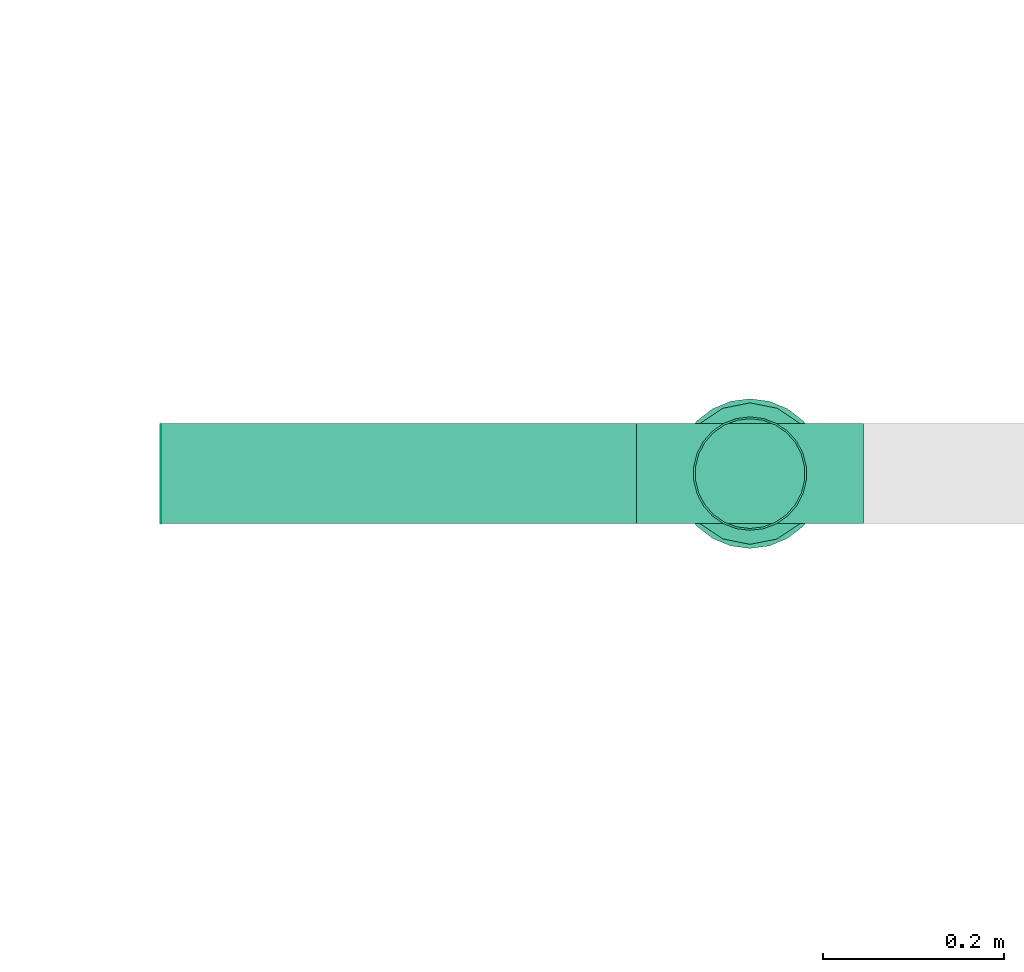
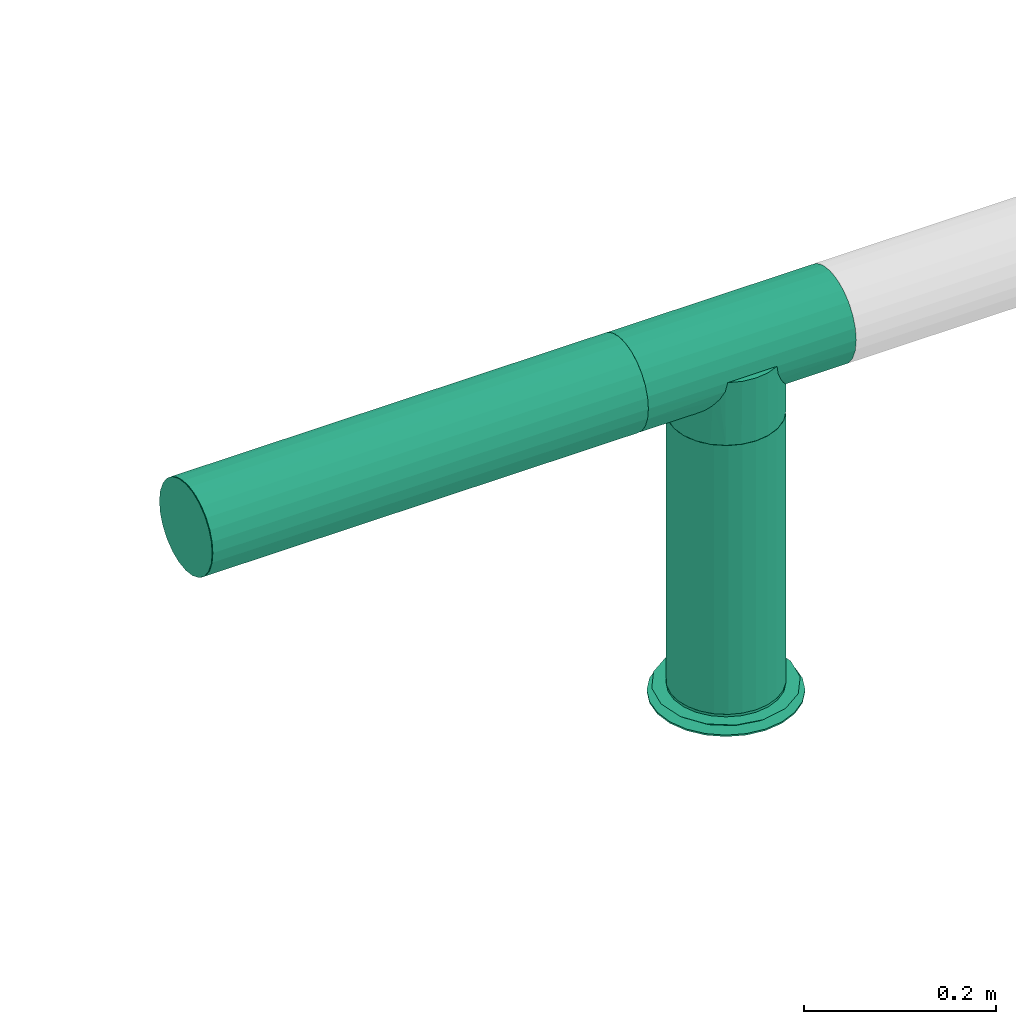
# One storey, part 41 of 123: 2 flow fittings, 2 flow segments, 1 flow terminal.
"""IFC2X3 building model written with IfcOpenShell, lengths in millimetres."""

from ifc_helpers import new_model, entity, si_unit, converted_unit, derived_unit, direction, frame, origin_with_axes, origin_2d_with_axis, place, context, subcontext, project, spatial, hollow_circle, extrude, open_shell, surface_model, source, transform, mapped, material, layer, layer_set, layer_usage, type_object, element, save


model = new_model("IFC2X3")

# Units and contexts
model_context = context("Model", 3, precision=1e-05, world=origin_with_axes(), true_north=direction((0.0, 1.0)))
body_context = subcontext(model_context, "Body", "Model", "MODEL_VIEW")
ifc_project = project(units=[si_unit("AREAUNIT", "SQUARE_METRE"), si_unit("VOLUMEUNIT", "CUBIC_METRE", prefix="DECI"), si_unit("TIMEUNIT", "SECOND"), si_unit("THERMODYNAMICTEMPERATUREUNIT", "DEGREE_CELSIUS"), si_unit("PRESSUREUNIT", "PASCAL"), si_unit("MASSUNIT", "GRAM", prefix="KILO"), si_unit("LENGTHUNIT", "METRE", prefix="MILLI"), si_unit("POWERUNIT", "WATT"), si_unit("ELECTRICCURRENTUNIT", "AMPERE"), si_unit("ELECTRICVOLTAGEUNIT", "VOLT"), derived_unit("VOLUMETRICFLOWRATEUNIT", [(si_unit("VOLUMEUNIT", "CUBIC_METRE", prefix="DECI"), 1), (si_unit("TIMEUNIT", "SECOND"), -1)]), derived_unit("LINEARVELOCITYUNIT", [(si_unit("LENGTHUNIT", "METRE"), 1), (si_unit("TIMEUNIT", "SECOND"), -1)]), derived_unit("MASSDENSITYUNIT", [(si_unit("MASSUNIT", "GRAM", prefix="KILO"), 1), (si_unit("VOLUMEUNIT", "CUBIC_METRE"), -1)]), converted_unit("PLANEANGLEUNIT", "DEGREE", entity("IfcRatioMeasure", 0.01745), si_unit("PLANEANGLEUNIT", "RADIAN"), dimensions=[0, 0, 0, 0, 0, 0, 0])], contexts=[model_context])

# Site, building, storey
site_placement = place(None, origin_with_axes())
site = spatial("IfcSite", under=ifc_project, at=site_placement, CompositionType="ELEMENT")
building_placement = place(site_placement, origin_with_axes())
building = spatial("IfcBuilding", under=site, at=building_placement, Name="mc-building", CompositionType="ELEMENT")
storey_placement = place(building_placement, origin_with_axes())
storey = spatial("IfcBuildingStorey", under=building, at=storey_placement, Name="1. Korrus", CompositionType="ELEMENT", Elevation=0.0)

# Flow terminal
air_terminal_type = type_object("IfcAirTerminalType", Name="125", PredefinedType="NOTDEFINED")
shared_shape_1 = source(origin_with_axes(), body_context, "Body", "SurfaceModel", [
    surface_model("IfcShellBasedSurfaceModel", [(11.2, 41.25, -71.4471), (11.2, 0.0, -82.5), (11.2, 21.35257, -79.68888), (11.2, 71.4471, -41.25), (11.2, 58.33631, -58.33631), (11.2, 79.68888, -21.35257), (11.2, 82.5, 0.0), (11.2, -79.68888, -21.35257), (11.2, -41.25, -71.4471), (11.2, -21.35257, -79.68888), (11.2, -58.33631, -58.33631), (11.2, -71.4471, -41.25), (11.2, 79.68888, 21.35257), (11.2, 71.4471, 41.25), (11.2, 58.33631, 58.33631), (11.2, 41.25, 71.4471), (11.2, 21.35257, 79.68888), (11.2, -58.33631, 58.33631), (11.2, -21.35257, 79.68888), (11.2, 0.0, 82.5), (11.2, -79.68888, 21.35257), (11.2, -71.4471, 41.25), (11.2, -82.5, 0.0), (11.2, -41.25, 71.4471), (9.2, 21.35257, 79.68888), (9.2, -21.35257, 79.68888), (9.2, 0.0, 82.5), (9.2, 58.33631, 58.33631), (9.2, 41.25, 71.4471), (9.2, 71.4471, 41.25), (9.2, 79.68888, 21.35257), (9.2, -58.33631, 58.33631), (9.2, -41.25, 71.4471), (9.2, -79.68888, 21.35257), (9.2, -71.4471, 41.25), (9.2, -58.33631, -58.33631), (9.2, -82.5, 0.0), (9.2, 79.68888, -21.35257), (9.2, 41.25, -71.4471), (9.2, 71.4471, -41.25), (9.2, -41.25, -71.4471), (9.2, 58.33631, -58.33631), (9.2, 0.0, -82.5), (9.2, 21.35257, -79.68888), (9.2, -71.4471, -41.25), (9.2, -79.68888, -21.35257), (9.2, -21.35257, -79.68888), (9.2, 82.5, 0.0), (9.2, 19.5, 33.77499), (9.2, 0.0, 39.0), (9.2, -19.5, 33.77499), (9.2, -39.0, 0.0), (9.2, 33.77499, 19.5), (9.2, 39.0, 0.0), (9.2, -33.77499, 19.5), (9.2, 0.0, -39.0), (9.2, -33.77499, -19.5), (9.2, -19.5, -33.77499), (9.2, 33.77499, -19.5), (9.2, 19.5, -33.77499), (6.2, 25.24133, 18.3389), (6.2, 31.2, 0.0), (6.2, 9.64133, 29.67296), (6.2, -25.24133, 18.3389), (6.2, -9.64133, 29.67296), (6.2, -31.2, 0.0), (6.2, 25.24133, -18.3389), (6.2, 9.64133, -29.67296), (6.2, -9.64133, -29.67296), (6.2, -25.24133, -18.3389), (9.2, 37.1621, -6.85914), (6.2, 28.22067, -9.16945), (9.2, 35.3242, -13.71829), (6.2, -17.44133, -24.00593), (9.2, -26.6375, -26.6375), (6.2, -28.22067, -9.16945), (9.2, -37.1621, -6.85914), (6.2, 17.44133, -24.00593), (9.2, 9.75, -36.3875), (6.2, 0.0, -29.67296), (9.2, -35.3242, -13.71829), (9.2, 26.6375, -26.6375), (9.2, -9.75, -36.3875), (9.2, -37.1621, 6.85914), (6.2, -28.22067, 9.16945), (9.2, -35.3242, 13.71829), (6.2, 17.44133, 24.00593), (9.2, 26.6375, 26.6375), (6.2, 28.22067, 9.16945), (9.2, 37.1621, 6.85914), (6.2, -17.44133, 24.00593), (9.2, -9.75, 36.3875), (6.2, 0.0, 29.67296), (9.2, 35.3242, 13.71829), (9.2, -26.6375, 26.6375), (9.2, 9.75, 36.3875), (6.2, -26.86438, 64.85634), (6.2, -49.63889, 49.63889), (6.2, -64.85634, 26.86438), (6.2, -70.2, 0.0), (6.2, 64.85634, 26.86438), (6.2, 0.0, 70.2), (6.2, 26.86438, 64.85634), (6.2, 49.63889, 49.63889), (6.2, 70.2, 0.0), (6.2, -64.85634, -26.86438), (6.2, -49.63889, -49.63889), (6.2, -26.86438, -64.85634), (6.2, 26.86438, -64.85634), (6.2, 0.0, -70.2), (6.2, 64.85634, -26.86438), (6.2, 49.63889, -49.63889), (0.0, -29.84931, 72.0626), (0.0, 0.0, 78.0), (0.0, 29.84931, 72.0626), (0.0, 55.15433, 55.15433), (0.0, 78.0, 0.0), (0.0, -55.15433, 55.15433), (0.0, -72.0626, 29.84931), (0.0, -78.0, 0.0), (0.0, 72.0626, 29.84931), (0.0, -72.0626, -29.84931), (0.0, 72.0626, -29.84931), (0.0, 55.15433, -55.15433), (0.0, 29.84931, -72.0626), (0.0, -55.15433, -55.15433), (0.0, -29.84931, -72.0626), (0.0, 0.0, -78.0), (6.2, 66.75025, -17.34304), (0.0, 63.60847, -42.50182), (6.2, 57.24762, -38.25164), (0.0, -14.92465, -75.0313), (6.2, -13.43219, -67.52817), (0.0, 42.50182, -63.60847), (6.2, 38.25164, -57.24762), (0.0, 75.0313, -14.92465), (0.0, 14.92465, -75.0313), (6.2, 13.43219, -67.52817), (0.0, -74.16695, -19.27005), (6.2, -67.52817, -13.43219), (0.0, -42.50182, -63.60847), (6.2, -38.25164, -57.24762), (0.0, -63.60847, -42.50182), (6.2, -57.24762, -38.25164), (6.2, -66.75025, 17.34304), (0.0, -63.60847, 42.50182), (6.2, -57.24762, 38.25164), (0.0, 14.92465, 75.0313), (6.2, 13.43219, 67.52817), (0.0, -42.50182, 63.60847), (6.2, -38.25164, 57.24762), (0.0, -75.0313, 14.92465), (0.0, -14.92465, 75.0313), (6.2, -13.43219, 67.52817), (0.0, 74.16695, 19.27005), (6.2, 67.52817, 13.43219), (0.0, 42.50182, 63.60847), (6.2, 38.25164, 57.24762), (0.0, 63.60847, 42.50182), (6.2, 57.24762, 38.25164), (-3.1, 16.17619, 60.37037), (-3.1, -31.25, 54.12659), (-3.1, 0.0, 62.5), (-3.1, 54.12659, 31.25), (-3.1, 31.25, 54.12659), (-3.1, 44.19417, 44.19417), (-3.1, -54.12659, -31.25), (-3.1, -54.12659, 31.25), (-3.1, -44.19417, 44.19417), (-3.1, -16.17619, 60.37037), (-3.1, -62.5, 0.0), (-3.1, -60.37037, 16.17619), (-3.1, 60.37037, 16.17619), (-3.1, 62.5, 0.0), (-3.1, 60.37037, -16.17619), (-3.1, 54.12659, -31.25), (-3.1, 44.19417, -44.19417), (-3.1, 31.25, -54.12659), (-3.1, 16.17619, -60.37037), (-3.1, -31.25, -54.12659), (-3.1, -44.19417, -44.19417), (-3.1, -60.37037, -16.17619), (-3.1, 0.0, -62.5), (-3.1, -16.17619, -60.37037), (0.0, 31.25, -54.12659), (0.0, -54.12659, -31.25), (0.0, 16.17619, -60.37037), (0.0, 54.12659, -31.25), (0.0, 44.19417, -44.19417), (0.0, 60.37037, -16.17619), (0.0, 62.5, 0.0), (0.0, 54.12659, 31.25), (0.0, 16.17619, 60.37037), (0.0, 0.0, -62.5), (0.0, -31.25, -54.12659), (0.0, -16.17619, -60.37037), (0.0, -44.19417, -44.19417), (0.0, -62.5, 0.0), (0.0, -60.37037, -16.17619), (0.0, 44.19417, 44.19417), (0.0, -54.12659, 31.25), (0.0, 31.25, 54.12659), (0.0, 0.0, 62.5), (0.0, -60.37037, 16.17619), (0.0, -31.25, 54.12659), (0.0, -44.19417, 44.19417), (0.0, -16.17619, 60.37037), (0.0, 60.37037, 16.17619), (-43.1, -14.75269, 55.05777), (-43.1, 0.0, 57.0), (-43.1, 14.75269, 55.05777), (-43.1, 28.5, 49.36345), (-43.1, 40.30508, 40.30508), (-43.1, 49.36345, 28.5), (-43.1, 55.05777, 14.75269), (-43.1, -28.5, 49.36345), (-43.1, -49.36345, 28.5), (-43.1, -40.30508, 40.30508), (-43.1, -57.0, 0.0), (-43.1, -55.05777, 14.75269), (-43.1, -40.30508, -40.30508), (-43.1, 57.0, 0.0), (-43.1, 55.05777, -14.75269), (-43.1, 28.5, -49.36345), (-43.1, 49.36345, -28.5), (-43.1, 14.75269, -55.05777), (-43.1, 40.30508, -40.30508), (-43.1, -49.36345, -28.5), (-43.1, -55.05777, -14.75269), (-43.1, -28.5, -49.36345), (-43.1, 0.0, -57.0), (-43.1, -14.75269, -55.05777), (-3.1, 57.0, 0.0), (-3.1, 14.75269, -55.05777), (-3.1, 28.5, -49.36345), (-3.1, 55.05777, -14.75269), (-3.1, 40.30508, -40.30508), (-3.1, 49.36345, -28.5), (-3.1, 55.05777, 14.75269), (-3.1, -28.5, -49.36345), (-3.1, 0.0, -57.0), (-3.1, -14.75269, -55.05777), (-3.1, -49.36345, -28.5), (-3.1, -57.0, 0.0), (-3.1, -55.05777, -14.75269), (-3.1, -40.30508, -40.30508), (-3.1, -49.36345, 28.5), (-3.1, 49.36345, 28.5), (-3.1, 40.30508, 40.30508), (-3.1, 0.0, 57.0), (-3.1, 28.5, 49.36345), (-3.1, 14.75269, 55.05777), (-3.1, -14.75269, 55.05777), (-3.1, -55.05777, 14.75269), (-3.1, -28.5, 49.36345), (-3.1, -40.30508, 40.30508)], [open_shell([[[0, 1, 2]], [[3, 0, 4]], [[5, 6, 0]], [[5, 0, 3]], [[7, 0, 6]], [[1, 8, 9]], [[1, 0, 8]], [[10, 7, 11]], [[10, 8, 0]], [[7, 10, 0]], [[6, 12, 7]], [[12, 13, 14]], [[12, 14, 15]], [[12, 16, 17]], [[16, 12, 15]], [[18, 16, 19]], [[20, 17, 21]], [[22, 7, 20]], [[17, 18, 23]], [[20, 12, 17]], [[16, 18, 17]], [[20, 7, 12]], [[24, 25, 26]], [[27, 24, 28]], [[27, 29, 30]], [[27, 30, 24]], [[31, 24, 30]], [[25, 31, 32]], [[25, 24, 31]], [[31, 33, 34]], [[31, 30, 33]], [[35, 36, 33]], [[33, 30, 37]], [[33, 37, 35]], [[38, 37, 39]], [[40, 37, 38]], [[38, 39, 41]], [[42, 38, 43]], [[36, 44, 45]], [[35, 44, 36]], [[40, 42, 46]], [[35, 37, 40]], [[38, 42, 40]], [[37, 30, 47]], [[45, 7, 36]], [[44, 11, 45]], [[8, 35, 40]], [[44, 35, 10]], [[9, 40, 46]], [[45, 11, 7]], [[7, 22, 36]], [[9, 8, 40]], [[10, 35, 8]], [[10, 11, 44]], [[1, 9, 46]], [[46, 42, 1]], [[43, 2, 42]], [[38, 0, 43]], [[3, 41, 39]], [[38, 41, 4]], [[5, 39, 37]], [[38, 4, 0]], [[0, 2, 43]], [[6, 5, 37]], [[3, 39, 5]], [[3, 4, 41]], [[47, 6, 37]], [[42, 2, 1]], [[30, 12, 47]], [[29, 13, 30]], [[15, 27, 28]], [[29, 27, 14]], [[16, 28, 24]], [[30, 13, 12]], [[12, 6, 47]], [[16, 15, 28]], [[14, 27, 15]], [[14, 13, 29]], [[19, 16, 24]], [[24, 26, 19]], [[25, 18, 26]], [[32, 23, 25]], [[21, 31, 34]], [[32, 31, 17]], [[20, 34, 33]], [[32, 17, 23]], [[23, 18, 25]], [[36, 22, 20]], [[21, 34, 20]], [[21, 17, 31]], [[33, 36, 20]], [[26, 18, 19]], [[48, 49, 50]], [[50, 51, 52]], [[50, 52, 48]], [[53, 52, 51]], [[50, 54, 51]], [[55, 51, 56]], [[55, 56, 57]], [[58, 55, 59]], [[58, 53, 55]], [[55, 53, 51]], [[60, 61, 62]], [[62, 63, 64]], [[65, 63, 62]], [[62, 61, 65]], [[66, 67, 68]], [[65, 68, 69]], [[65, 61, 68]], [[68, 61, 66]], [[61, 70, 71]], [[58, 71, 72]], [[73, 74, 69]], [[56, 75, 69]], [[76, 51, 65]], [[59, 67, 77]], [[73, 68, 57]], [[74, 73, 57]], [[67, 78, 79]], [[70, 61, 53]], [[65, 75, 76]], [[56, 80, 75]], [[66, 81, 77]], [[82, 57, 68]], [[67, 59, 78]], [[59, 77, 81]], [[81, 66, 58]], [[71, 58, 66]], [[82, 79, 55]], [[78, 55, 79]], [[68, 79, 82]], [[75, 80, 76]], [[56, 69, 74]], [[70, 72, 71]], [[65, 83, 84]], [[54, 84, 85]], [[86, 87, 60]], [[52, 88, 60]], [[89, 53, 61]], [[50, 64, 90]], [[86, 62, 48]], [[87, 86, 48]], [[64, 91, 92]], [[83, 65, 51]], [[61, 88, 89]], [[52, 93, 88]], [[63, 94, 90]], [[95, 48, 62]], [[64, 50, 91]], [[50, 90, 94]], [[94, 63, 54]], [[84, 54, 63]], [[95, 92, 49]], [[91, 49, 92]], [[62, 92, 95]], [[88, 93, 89]], [[52, 60, 87]], [[83, 85, 84]], [[96, 97, 98]], [[98, 99, 96]], [[96, 99, 100]], [[101, 96, 102]], [[100, 103, 102]], [[96, 100, 102]], [[99, 104, 100]], [[105, 106, 107]], [[105, 107, 108]], [[108, 107, 109]], [[110, 104, 111]], [[108, 111, 104]], [[99, 108, 104]], [[108, 99, 105]], [[112, 113, 114]], [[112, 114, 115]], [[116, 112, 115]], [[117, 112, 118]], [[119, 118, 112]], [[119, 112, 116]], [[116, 115, 120]], [[121, 116, 122]], [[123, 124, 122]], [[121, 122, 124]], [[125, 121, 126]], [[126, 121, 124]], [[124, 127, 126]], [[116, 121, 119]], [[110, 122, 128]], [[111, 129, 130]], [[107, 131, 132]], [[108, 133, 134]], [[104, 128, 135]], [[116, 104, 135]], [[111, 134, 123]], [[130, 122, 110]], [[136, 124, 137]], [[128, 122, 135]], [[127, 136, 109]], [[111, 123, 129]], [[119, 138, 139]], [[138, 105, 139]], [[140, 141, 106]], [[124, 108, 137]], [[139, 99, 119]], [[108, 124, 133]], [[106, 125, 140]], [[142, 143, 105]], [[123, 134, 133]], [[131, 127, 132]], [[106, 143, 125]], [[141, 126, 107]], [[126, 141, 140]], [[109, 136, 137]], [[138, 121, 105]], [[122, 130, 129]], [[125, 143, 142]], [[107, 126, 131]], [[127, 109, 132]], [[105, 121, 142]], [[98, 118, 144]], [[97, 145, 146]], [[102, 147, 148]], [[96, 149, 150]], [[99, 144, 151]], [[119, 99, 151]], [[97, 150, 117]], [[146, 118, 98]], [[152, 112, 153]], [[144, 118, 151]], [[113, 152, 101]], [[97, 117, 145]], [[116, 154, 155]], [[154, 100, 155]], [[156, 157, 103]], [[112, 96, 153]], [[155, 104, 116]], [[96, 112, 149]], [[103, 115, 156]], [[158, 159, 100]], [[117, 150, 149]], [[147, 113, 148]], [[103, 159, 115]], [[157, 114, 102]], [[114, 157, 156]], [[101, 152, 153]], [[154, 120, 100]], [[118, 146, 145]], [[115, 159, 158]], [[102, 114, 147]], [[113, 101, 148]], [[100, 120, 158]], [[160, 161, 162]], [[163, 160, 164]], [[161, 160, 163]], [[163, 164, 165]], [[163, 166, 167]], [[161, 167, 168]], [[161, 169, 162]], [[167, 170, 171]], [[167, 161, 163]], [[166, 170, 167]], [[163, 172, 173]], [[173, 174, 175]], [[173, 175, 176]], [[177, 178, 173]], [[177, 173, 176]], [[173, 178, 179]], [[166, 179, 180]], [[181, 170, 166]], [[179, 182, 183]], [[166, 163, 179]], [[182, 179, 178]], [[163, 173, 179]], [[184, 185, 186]], [[187, 184, 188]], [[187, 189, 190]], [[184, 187, 191]], [[192, 185, 184]], [[193, 194, 195]], [[193, 186, 194]], [[194, 185, 196]], [[186, 185, 194]], [[185, 197, 198]], [[190, 191, 187]], [[191, 192, 184]], [[192, 191, 199]], [[192, 200, 185]], [[192, 199, 201]], [[202, 200, 192]], [[197, 200, 203]], [[185, 200, 197]], [[200, 204, 205]], [[202, 204, 200]], [[202, 206, 204]], [[191, 190, 207]], [[172, 207, 173]], [[163, 191, 172]], [[201, 165, 164]], [[163, 165, 199]], [[192, 164, 160]], [[172, 191, 207]], [[207, 190, 173]], [[192, 201, 164]], [[199, 165, 201]], [[199, 191, 163]], [[202, 192, 160]], [[160, 162, 202]], [[169, 206, 162]], [[161, 204, 169]], [[200, 168, 167]], [[161, 168, 205]], [[203, 167, 171]], [[161, 205, 204]], [[204, 206, 169]], [[197, 203, 171]], [[200, 167, 203]], [[200, 205, 168]], [[170, 197, 171]], [[162, 206, 202]], [[181, 198, 170]], [[166, 185, 181]], [[194, 180, 179]], [[166, 180, 196]], [[195, 179, 183]], [[181, 185, 198]], [[198, 197, 170]], [[195, 194, 179]], [[196, 180, 194]], [[196, 185, 166]], [[193, 195, 183]], [[183, 182, 193]], [[178, 186, 182]], [[177, 184, 178]], [[187, 176, 175]], [[177, 176, 188]], [[189, 175, 174]], [[177, 188, 184]], [[184, 186, 178]], [[190, 189, 174]], [[187, 175, 189]], [[187, 188, 176]], [[173, 190, 174]], [[182, 186, 193]], [[208, 209, 210]], [[211, 208, 210]], [[212, 213, 214]], [[212, 214, 211]], [[208, 211, 214]], [[215, 216, 217]], [[216, 215, 208]], [[216, 218, 219]], [[216, 208, 214]], [[216, 220, 218]], [[216, 214, 221]], [[220, 216, 222]], [[223, 222, 224]], [[223, 225, 222]], [[223, 224, 226]], [[220, 222, 225]], [[218, 227, 228]], [[220, 227, 218]], [[229, 230, 231]], [[229, 220, 225]], [[230, 229, 225]], [[216, 221, 222]], [[232, 233, 234]], [[235, 234, 236]], [[235, 232, 234]], [[235, 236, 237]], [[238, 239, 233]], [[240, 239, 241]], [[240, 233, 239]], [[242, 243, 244]], [[245, 239, 246]], [[242, 245, 243]], [[238, 233, 232]], [[238, 247, 248]], [[238, 248, 249]], [[250, 251, 249]], [[250, 249, 248]], [[238, 249, 252]], [[243, 246, 253]], [[245, 246, 243]], [[246, 254, 255]], [[254, 246, 252]], [[238, 252, 246]], [[246, 239, 238]], [[214, 238, 221]], [[213, 247, 214]], [[250, 212, 211]], [[213, 212, 248]], [[251, 211, 210]], [[214, 247, 238]], [[238, 232, 221]], [[251, 250, 211]], [[248, 212, 250]], [[248, 247, 213]], [[249, 251, 210]], [[210, 209, 249]], [[254, 215, 217]], [[246, 216, 219]], [[217, 216, 255]], [[253, 219, 218]], [[208, 254, 252]], [[208, 215, 254]], [[252, 249, 208]], [[217, 255, 254]], [[216, 246, 255]], [[253, 246, 219]], [[218, 243, 253]], [[208, 249, 209]], [[228, 244, 218]], [[227, 242, 228]], [[239, 220, 229]], [[227, 220, 245]], [[241, 229, 231]], [[228, 242, 244]], [[244, 243, 218]], [[241, 239, 229]], [[245, 220, 239]], [[245, 242, 227]], [[240, 241, 231]], [[231, 230, 240]], [[233, 230, 225]], [[234, 225, 223]], [[237, 224, 222]], [[221, 235, 222]], [[225, 234, 233]], [[234, 223, 226]], [[234, 226, 236]], [[226, 224, 236]], [[224, 237, 236]], [[235, 237, 222]], [[221, 232, 235]], [[230, 233, 240]]])]),
])
flow_terminal_placement = place(storey_placement, frame((12118.92187, 6092.2195, 2200.0), z_axis=(1.0, 0.0, 0.0), x_axis=(0.0, 0.0, -1.0)))
element("IfcFlowTerminal", 1, at=flow_terminal_placement, inside=storey, type_object=air_terminal_type, Name="125", context=body_context, shape_type="MappedRepresentation", body=[
    mapped(shared_shape_1, transform((0.0, 0.0, 0.0), scale=1.0)),
])

# Flow segments
ifc_material = material(Name="FZ1")
ifc_layer = layer(ifc_material, 0.0)
ifc_layer_set = layer_set([ifc_layer], Name="FZ1")
ifc_layer_usage = layer_usage(ifc_layer_set, "AXIS1", "POSITIVE", 0.0)
duct_segment_type = type_object("IfcDuctSegmentType", PredefinedType="RIGIDSEGMENT")
shared_shape_2 = source(origin_with_axes(), body_context, "Body", "SweptSolid", [
    extrude(hollow_circle(Radius=62.5, WallThickness=2.0, at=origin_2d_with_axis()), frame((0.0, 0.0, 0.0), z_axis=(1.0, 0.0, 0.0), x_axis=(0.0, 1.0, 0.0)), (0.0, 0.0, 1.0), 341.9),
])
flow_segment_1_placement = place(storey_placement, frame((12118.92187, 6092.2195, 2545.0), z_axis=(1.0, 0.0, 0.0), x_axis=(0.0, 0.0, -1.0)))
element("IfcFlowSegment", 2, at=flow_segment_1_placement, inside=storey, type_object=duct_segment_type, material=ifc_layer_usage, context=body_context, shape_type="MappedRepresentation", body=[
    mapped(shared_shape_2, transform((0.0, 0.0, 0.0), scale=1.0)),
])
shared_shape_3 = source(origin_with_axes(), body_context, "Body", "SweptSolid", [
    extrude(hollow_circle(Radius=55.0, WallThickness=2.0, at=origin_2d_with_axis()), frame((0.0, 0.0, 0.0), z_axis=(1.0, 0.0, 0.0), x_axis=(0.0, 1.0, 0.0)), (0.0, 0.0, 1.0), 523.9),
])
flow_segment_2_placement = place(storey_placement, frame((11993.92187, 6092.2195, 2625.0), z_axis=(0.0, 0.0, 1.0), x_axis=(-1.0, 0.0, 0.0)))
element("IfcFlowSegment", 3, at=flow_segment_2_placement, inside=storey, type_object=duct_segment_type, material=ifc_layer_usage, context=body_context, shape_type="MappedRepresentation", body=[
    mapped(shared_shape_3, transform((0.0, 0.0, 0.0), scale=1.0)),
])

# Flow fittings
duct_fitting_type_1 = type_object("IfcDuctFittingType", PredefinedType="JUNCTION")
shared_shape_4 = source(origin_with_axes(), body_context, "Body", "SurfaceModel", [
    surface_model("IfcShellBasedSurfaceModel", [(0.0, -80.0, -62.5), (16.17619, -80.0, -60.37037), (-16.17619, -80.0, -60.37037), (-60.37037, -80.0, 16.17619), (-31.25, -80.0, -54.12659), (-44.19417, -80.0, -44.19417), (-54.12659, -80.0, -31.25), (62.5, -80.0, 0.0), (60.37037, -80.0, 16.17619), (44.19417, -80.0, -44.19417), (31.25, -80.0, -54.12659), (60.37037, -80.0, -16.17619), (54.12659, -80.0, -31.25), (-60.37037, -80.0, -16.17619), (-54.12659, -80.0, 31.25), (-44.19417, -80.0, 44.19417), (-31.25, -80.0, 54.12659), (-16.17619, -80.0, 60.37037), (16.17619, -80.0, 60.37037), (54.12659, -80.0, 31.25), (44.19417, -80.0, 44.19417), (31.25, -80.0, 54.12659), (0.0, -80.0, 62.5), (-62.5, -80.0, 0.0), (0.0, 0.0, 62.5), (-15.31424, 0.0, 60.59475), (-29.68586, 0.0, 55.0), (-31.79332, -11.38268, 53.80924), (-62.5, -55.0, 0.0), (-61.43518, -80.0, 8.0881), (-61.42389, -53.77401, 11.548), (-36.65815, -21.50744, 50.62045), (-42.49909, -30.41254, 45.8266), (-48.42243, -38.25549, 39.51605), (-53.88367, -44.96887, 31.66703), (-58.39386, -50.28512, 22.28019), (-61.42389, -53.77401, -11.548), (-58.39386, -50.28512, -22.28019), (-53.88367, -44.96887, -31.66703), (-48.42243, -38.25549, -39.51605), (-61.43518, -80.0, -8.0881), (-42.49909, -30.41254, -45.8266), (-31.79332, -11.38268, -53.80924), (-29.68586, 0.0, -55.0), (-15.31424, 0.0, -60.59475), (0.0, 0.0, -62.5), (-36.65815, -21.50744, -50.62045), (15.31424, 0.0, -60.59475), (29.68586, 0.0, -55.0), (31.79332, -11.38268, -53.80924), (62.5, -55.0, 0.0), (61.43518, -80.0, -8.0881), (61.42389, -53.77401, -11.548), (36.65815, -21.50744, -50.62045), (42.49909, -30.41254, -45.8266), (48.42243, -38.25549, -39.51605), (53.88367, -44.96887, -31.66703), (58.39386, -50.28512, -22.28019), (61.42389, -53.77401, 11.548), (58.39386, -50.28512, 22.28019), (53.88367, -44.96887, 31.66703), (48.42243, -38.25549, 39.51605), (61.43518, -80.0, 8.0881), (42.49909, -30.41254, 45.8266), (31.79332, -11.38268, 53.80924), (29.68586, 0.0, 55.0), (15.31424, 0.0, 60.59475), (36.65815, -21.50744, 50.62045), (-125.0, 0.0, -55.0), (-125.0, -14.23505, -53.12592), (-125.0, 14.23505, -53.12592), (-125.0, 53.12592, 14.23505), (-125.0, 27.5, -47.63139), (-125.0, 47.63139, -27.5), (-125.0, 38.89087, -38.89087), (-125.0, -55.0, 0.0), (-125.0, -53.12592, 14.23505), (-125.0, -38.89087, -38.89087), (-125.0, -27.5, -47.63139), (-125.0, -53.12592, -14.23505), (-125.0, -47.63139, -27.5), (-125.0, 53.12592, -14.23505), (-125.0, 47.63139, 27.5), (-125.0, 38.89087, 38.89087), (-125.0, -14.23505, 53.12592), (-125.0, 27.5, 47.63139), (-125.0, 14.23505, 53.12592), (-125.0, -47.63139, 27.5), (-125.0, -38.89087, 38.89087), (-125.0, -27.5, 47.63139), (-125.0, 0.0, 55.0), (-125.0, 55.0, 0.0), (125.0, 55.0, 0.0), (125.0, 0.0, -55.0), (125.0, 14.23505, -53.12592), (125.0, 27.5, -47.63139), (125.0, 38.89087, -38.89087), (125.0, 47.63139, -27.5), (125.0, -38.89087, -38.89087), (125.0, -53.12592, 14.23505), (125.0, -27.5, -47.63139), (125.0, -14.23505, -53.12592), (125.0, -47.63139, -27.5), (125.0, -53.12592, -14.23505), (125.0, -55.0, 0.0), (125.0, 53.12592, -14.23505), (125.0, 53.12592, 14.23505), (125.0, 47.63139, 27.5), (125.0, 38.89087, 38.89087), (125.0, 0.0, 55.0), (125.0, 27.5, 47.63139), (125.0, 14.23505, 53.12592), (125.0, -47.63139, 27.5), (125.0, -38.89087, 38.89087), (125.0, -27.5, 47.63139), (125.0, -14.23505, 53.12592)], [open_shell([[[0, 1, 2]], [[2, 3, 4]], [[5, 3, 6]], [[4, 3, 5]], [[2, 7, 8]], [[9, 7, 10]], [[1, 10, 7]], [[11, 7, 12]], [[9, 12, 7]], [[7, 2, 1]], [[13, 6, 3]], [[2, 14, 3]], [[2, 15, 14]], [[16, 2, 17]], [[16, 15, 2]], [[17, 2, 18]], [[19, 20, 2]], [[19, 2, 8]], [[20, 21, 2]], [[2, 21, 18]], [[18, 22, 17]], [[23, 13, 3]], [[22, 24, 25]], [[26, 27, 25]], [[28, 29, 30]], [[17, 25, 27]], [[22, 25, 17]], [[16, 31, 32]], [[16, 17, 27]], [[16, 32, 15]], [[31, 16, 27]], [[33, 34, 14]], [[35, 30, 3]], [[34, 35, 14]], [[15, 33, 14]], [[30, 29, 3]], [[3, 14, 35]], [[29, 28, 23]], [[33, 15, 32]], [[36, 37, 13]], [[38, 39, 6]], [[37, 38, 6]], [[36, 40, 28]], [[28, 40, 23]], [[13, 37, 6]], [[39, 5, 6]], [[39, 41, 5]], [[42, 43, 44]], [[36, 13, 40]], [[42, 44, 2]], [[0, 44, 45]], [[41, 46, 4]], [[42, 4, 46]], [[42, 2, 4]], [[44, 0, 2]], [[41, 4, 5]], [[0, 45, 47]], [[48, 49, 47]], [[50, 51, 52]], [[1, 47, 49]], [[0, 47, 1]], [[10, 53, 54]], [[10, 1, 49]], [[10, 54, 9]], [[53, 10, 49]], [[55, 56, 12]], [[57, 52, 11]], [[56, 57, 12]], [[9, 55, 12]], [[52, 51, 11]], [[11, 12, 57]], [[51, 50, 7]], [[55, 9, 54]], [[58, 59, 8]], [[60, 61, 19]], [[59, 60, 19]], [[58, 62, 50]], [[7, 50, 62]], [[59, 19, 8]], [[61, 20, 19]], [[61, 63, 20]], [[64, 65, 66]], [[58, 8, 62]], [[64, 66, 18]], [[22, 66, 24]], [[63, 67, 21]], [[64, 21, 67]], [[64, 18, 21]], [[66, 22, 18]], [[63, 21, 20]], [[68, 69, 70]], [[70, 71, 72]], [[73, 74, 71]], [[72, 71, 74]], [[70, 75, 76]], [[77, 75, 78]], [[69, 78, 75]], [[79, 75, 80]], [[77, 80, 75]], [[75, 70, 69]], [[73, 71, 81]], [[70, 82, 71]], [[70, 83, 82]], [[70, 84, 85]], [[85, 83, 70]], [[84, 86, 85]], [[70, 87, 88]], [[87, 70, 76]], [[88, 89, 70]], [[70, 89, 84]], [[84, 90, 86]], [[91, 81, 71]], [[92, 93, 94]], [[95, 92, 94]], [[92, 96, 97]], [[96, 92, 95]], [[98, 93, 99]], [[93, 98, 100]], [[100, 101, 93]], [[98, 99, 102]], [[102, 99, 103]], [[104, 103, 99]], [[105, 92, 97]], [[106, 107, 93]], [[93, 107, 108]], [[109, 93, 110]], [[93, 108, 110]], [[109, 110, 111]], [[112, 99, 93]], [[113, 112, 93]], [[114, 113, 93]], [[115, 114, 93]], [[115, 93, 109]], [[92, 106, 93]], [[65, 109, 111]], [[65, 111, 86]], [[85, 111, 110]], [[90, 26, 86]], [[86, 26, 65]], [[111, 85, 86]], [[110, 83, 85]], [[82, 108, 107]], [[71, 107, 106]], [[91, 106, 92]], [[83, 108, 82]], [[82, 107, 71]], [[106, 91, 71]], [[108, 83, 110]], [[81, 92, 105]], [[73, 105, 97]], [[74, 97, 96]], [[91, 92, 81]], [[81, 105, 73]], [[97, 74, 73]], [[96, 72, 74]], [[70, 95, 94]], [[93, 48, 94]], [[43, 94, 48]], [[72, 95, 70]], [[43, 68, 70]], [[94, 43, 70]], [[95, 72, 96]], [[68, 43, 42]], [[69, 42, 46]], [[78, 46, 41]], [[68, 42, 69]], [[77, 41, 39]], [[78, 69, 46]], [[41, 77, 78]], [[38, 37, 80]], [[36, 28, 75]], [[37, 36, 79]], [[77, 38, 80]], [[80, 37, 79]], [[36, 75, 79]], [[38, 77, 39]], [[49, 93, 101]], [[101, 100, 53]], [[98, 54, 100]], [[98, 55, 54]], [[48, 93, 49]], [[49, 101, 53]], [[100, 54, 53]], [[56, 98, 102]], [[57, 102, 103]], [[52, 103, 104]], [[57, 56, 102]], [[50, 52, 104]], [[57, 103, 52]], [[98, 56, 55]], [[28, 30, 75]], [[35, 34, 87]], [[30, 35, 76]], [[75, 30, 76]], [[76, 35, 87]], [[34, 88, 87]], [[34, 33, 88]], [[89, 32, 31]], [[31, 27, 84]], [[26, 90, 27]], [[32, 88, 33]], [[32, 89, 88]], [[89, 31, 84]], [[27, 90, 84]], [[58, 104, 99]], [[59, 99, 112]], [[60, 112, 113]], [[58, 50, 104]], [[60, 59, 112]], [[58, 99, 59]], [[113, 61, 60]], [[61, 113, 63]], [[63, 113, 114]], [[67, 114, 115]], [[64, 115, 109]], [[63, 114, 67]], [[64, 67, 115]], [[65, 64, 109]], [[65, 26, 24]], [[65, 24, 66]], [[24, 26, 25]], [[47, 45, 48]], [[43, 48, 45]], [[43, 45, 44]]])]),
])
flow_fitting_1_placement = place(storey_placement, frame((12118.92187, 6092.2195, 2625.0), z_axis=(0.0, 1.0, 0.0), x_axis=(-1.0, 0.0, 0.0)))
element("IfcFlowFitting", 4, at=flow_fitting_1_placement, inside=storey, type_object=duct_fitting_type_1, context=body_context, shape_type="MappedRepresentation", body=[
    mapped(shared_shape_4, transform((0.0, 0.0, 0.0), scale=1.0)),
])
duct_fitting_type_2 = type_object("IfcDuctFittingType", Name="EPF", PredefinedType="OBSTRUCTION")
shared_shape_5 = source(origin_with_axes(), body_context, "Body", "SurfaceModel", [
    surface_model("IfcShellBasedSurfaceModel", [(0.0, -55.0, 0.0), (0.0, -53.12592, 14.23505), (0.0, 0.0, -55.0), (0.0, 14.23505, -53.12592), (0.0, 53.12592, 14.23505), (0.0, 27.5, -47.63139), (0.0, 47.63139, -27.5), (0.0, 38.89087, -38.89087), (0.0, -27.5, 47.63139), (0.0, -38.89087, -38.89087), (0.0, -27.5, -47.63139), (0.0, -14.23505, -53.12592), (0.0, -53.12592, -14.23505), (0.0, -47.63139, -27.5), (0.0, 53.12592, -14.23505), (0.0, 47.63139, 27.5), (0.0, 38.89087, 38.89087), (0.0, 14.23505, 53.12592), (0.0, 27.5, 47.63139), (0.0, -14.23505, 53.12592), (0.0, -47.63139, 27.5), (0.0, -38.89087, 38.89087), (0.0, 0.0, 55.0), (0.0, 55.0, 0.0), (0.8, 14.23505, -53.12592), (0.8, 53.12592, 14.23505), (0.8, 0.0, -55.0), (0.8, 27.5, -47.63139), (0.8, 55.0, 0.0), (0.8, 38.89087, -38.89087), (0.8, 47.63139, -27.5), (0.8, -38.89087, -38.89087), (0.8, -53.12592, 14.23505), (0.8, -27.5, -47.63139), (0.8, -14.23505, -53.12592), (0.8, -47.63139, -27.5), (0.8, -53.12592, -14.23505), (0.8, -55.0, 0.0), (0.8, 53.12592, -14.23505), (0.8, 47.63139, 27.5), (0.8, 38.89087, 38.89087), (0.8, 27.5, 47.63139), (0.8, 0.0, 55.0), (0.8, 14.23505, 53.12592), (0.8, -47.63139, 27.5), (0.8, -38.89087, 38.89087), (0.8, -27.5, 47.63139), (0.8, -14.23505, 53.12592)], [open_shell([[[0, 1, 2]], [[3, 4, 5]], [[6, 7, 4]], [[4, 7, 5]], [[2, 8, 3]], [[9, 0, 10]], [[11, 10, 0]], [[12, 0, 13]], [[9, 13, 0]], [[0, 2, 11]], [[4, 14, 6]], [[4, 3, 15]], [[16, 15, 3]], [[3, 17, 18]], [[16, 3, 18]], [[3, 19, 17]], [[2, 1, 20]], [[2, 20, 21]], [[2, 21, 8]], [[19, 3, 8]], [[19, 22, 17]], [[23, 14, 4]], [[24, 25, 26]], [[27, 25, 24]], [[28, 29, 30]], [[27, 29, 25]], [[31, 26, 32]], [[26, 31, 33]], [[33, 34, 26]], [[31, 32, 35]], [[35, 32, 36]], [[37, 36, 32]], [[28, 30, 38]], [[25, 39, 26]], [[26, 39, 40]], [[26, 41, 42]], [[41, 26, 40]], [[41, 43, 42]], [[44, 32, 26]], [[45, 44, 26]], [[46, 45, 26]], [[46, 26, 47]], [[42, 47, 26]], [[28, 25, 29]], [[22, 42, 43]], [[17, 43, 41]], [[22, 43, 17]], [[18, 40, 16]], [[18, 17, 41]], [[40, 18, 41]], [[15, 39, 25]], [[4, 25, 28]], [[16, 39, 15]], [[4, 15, 25]], [[23, 4, 28]], [[39, 16, 40]], [[23, 28, 38]], [[14, 38, 30]], [[23, 38, 14]], [[6, 29, 7]], [[6, 14, 30]], [[29, 6, 30]], [[5, 27, 24]], [[3, 24, 26]], [[7, 27, 5]], [[3, 5, 24]], [[2, 3, 26]], [[27, 7, 29]], [[2, 26, 34]], [[11, 34, 33]], [[2, 34, 11]], [[10, 31, 9]], [[10, 11, 33]], [[31, 10, 33]], [[13, 35, 36]], [[12, 36, 37]], [[9, 35, 13]], [[12, 13, 36]], [[0, 12, 37]], [[35, 9, 31]], [[0, 37, 32]], [[1, 32, 44]], [[0, 32, 1]], [[20, 45, 21]], [[20, 1, 44]], [[45, 20, 44]], [[8, 46, 47]], [[19, 47, 42]], [[21, 46, 8]], [[19, 8, 47]], [[22, 19, 42]], [[46, 21, 45]]])]),
])
flow_fitting_2_placement = place(storey_placement, frame((11469.98441, 6092.2195, 2625.0), z_axis=(0.0, 0.0, 1.0), x_axis=(-1.0, 0.0, 0.0)))
element("IfcFlowFitting", 5, at=flow_fitting_2_placement, inside=storey, type_object=duct_fitting_type_2, context=body_context, shape_type="MappedRepresentation", body=[
    mapped(shared_shape_5, transform((0.0, 0.0, 0.0), scale=1.0)),
])

save(model, "model.ifc")
